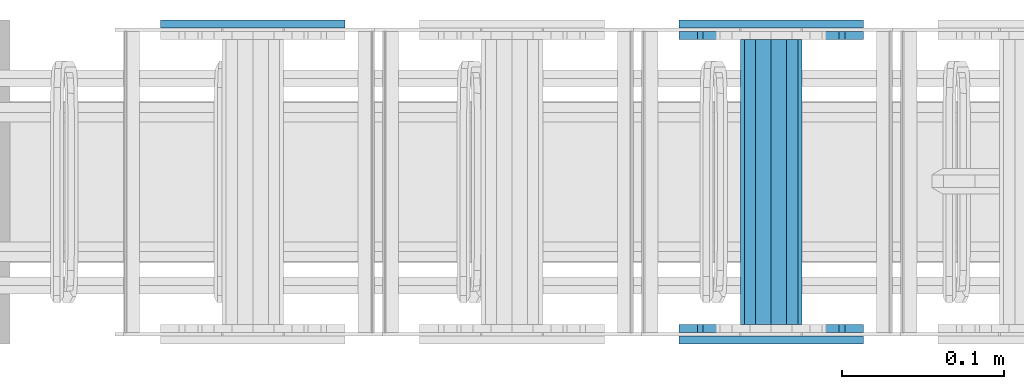
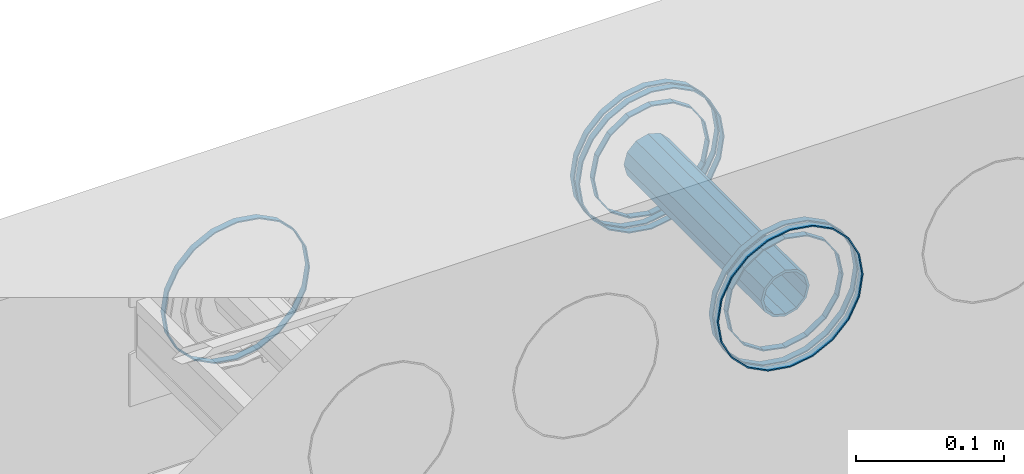
# One storey, part 3 of 11: 8 beams.
"""IFC2X3 building model written with IfcOpenShell, lengths in millimetres."""

import ifcopenshell
import ifcopenshell.guid

model = None  # the IFC model being written
_history = None  # IfcOwnerHistory: only IFC2X3 demands one
_inside = {}  # id of a spatial element -> (the spatial element, [elements in it])
_under = {}  # id of a project, library or spatial element -> (it, [spatial elements below it])
_declared = {}  # id of a project -> (the project, [libraries it declares])
_typed = {}  # id of a type object -> (the type object, [elements of that type])
_made_of = {}  # id of a material, layer set ... -> (it, [elements and type objects made of it])


def new_model(schema):
    """Start an empty IFC model of exactly this schema.

    Asked for "IFC4X3", IfcOpenShell would pick the latest addendum, in which some entities
    have other attributes; the version numbers below select the first issue.
    IFC2X3 requires an IfcOwnerHistory on every rooted entity: one is made here for all.
    """
    global model, _history
    if schema == "IFC4X3":
        model = ifcopenshell.file(schema_version=(4, 3, 0, 0))
    else:
        model = ifcopenshell.file(schema=schema)
    _inside.clear()
    _under.clear()
    _declared.clear()
    _typed.clear()
    _made_of.clear()
    _history = None
    if model.schema == "IFC2X3":
        org = make("IfcOrganization", Name="unknown")
        user = make(
            "IfcPersonAndOrganization",
            ThePerson=make("IfcPerson", FamilyName="unknown"),
            TheOrganization=org,
        )
        app = make(
            "IfcApplication",
            ApplicationDeveloper=org,
            Version="unknown",
            ApplicationFullName="unknown",
            ApplicationIdentifier="unknown",
        )
        _history = make(
            "IfcOwnerHistory",
            OwningUser=user,
            OwningApplication=app,
            ChangeAction="ADDED",
            CreationDate=0,
        )
    return model


def make(cls, **values):
    """One entity of the class cls with the attributes given. An attribute that is None is left unset."""
    return model.create_entity(
        cls, **{name: value for name, value in values.items() if value is not None}
    )


def rooted(cls, **values):
    """An entity with a GlobalId (a new one), such as an element, a storey or a relation."""
    return make(cls, GlobalId=ifcopenshell.guid.new(), OwnerHistory=_history, **values)


def si_unit(unit_type, name, prefix=None):
    """IfcSIUnit, for example si_unit("LENGTHUNIT", "METRE", prefix="MILLI")."""
    return make("IfcSIUnit", UnitType=unit_type, Prefix=prefix, Name=name)


def assignment(units):
    """IfcUnitAssignment: the units of a project."""
    return None if units is None else make("IfcUnitAssignment", Units=units)


def point(xyz):
    """IfcCartesianPoint."""
    return None if xyz is None else make("IfcCartesianPoint", Coordinates=xyz)


def direction(xyz):
    """IfcDirection."""
    return None if xyz is None else make("IfcDirection", DirectionRatios=xyz)


def frame(location, z_axis=None, x_axis=None):
    """IfcAxis2Placement3D, a coordinate frame: its origin and axes. An axis left out is left unset."""
    return make(
        "IfcAxis2Placement3D",
        Location=point(location),
        Axis=direction(z_axis),
        RefDirection=direction(x_axis),
    )


def origin_with_axes():
    """The frame at (0, 0, 0) with the z axis (0, 0, 1) and the x axis (1, 0, 0) written out."""
    return frame((0.0, 0.0, 0.0), z_axis=(0.0, 0.0, 1.0), x_axis=(1.0, 0.0, 0.0))


def place(relative_to, where):
    """IfcLocalPlacement: puts the frame where relative to a parent placement (None: the world)."""
    return make(
        "IfcLocalPlacement", PlacementRelTo=relative_to, RelativePlacement=where
    )


def context(
    kind, dimensions, precision=None, world=None, true_north=None, identifier=None
):
    """IfcGeometricRepresentationContext, for example the 3D "Model" context."""
    return make(
        "IfcGeometricRepresentationContext",
        ContextIdentifier=identifier,
        ContextType=kind,
        CoordinateSpaceDimension=dimensions,
        Precision=precision,
        WorldCoordinateSystem=world,
        TrueNorth=true_north,
    )


def subcontext(parent, identifier, kind, view, scale=None):
    """IfcGeometricRepresentationSubContext, for example "Body" below "Model"."""
    return make(
        "IfcGeometricRepresentationSubContext",
        ContextIdentifier=identifier,
        ContextType=kind,
        ParentContext=parent,
        TargetScale=scale,
        TargetView=view,
    )


def project(units=None, contexts=None):
    """IfcProject with its units and contexts."""
    return rooted(
        "IfcProject",
        Name="project",
        RepresentationContexts=contexts,
        UnitsInContext=assignment(units),
    )


def spatial(cls, under=None, at=None, **own):
    """A site, building, storey or space (cls), placed at a placement, below another one or the project."""
    s = rooted(cls, ObjectPlacement=at, **own)
    if under is not None:
        _under.setdefault(under.id(), (under, []))[1].append(s)
    return s


def faces_of(points, faces, orient=None, outer=None):
    """IfcFace entities. A face is a list of loops; a loop is a list of indices into points, from 0.

    orient and outer hold one flag for each loop. By default every Orientation is true, the
    first loop of a face is its IfcFaceOuterBound and the others are IfcFaceBound.
    """
    made = []
    for i, loops in enumerate(faces):
        bounds = []
        for j, loop in enumerate(loops):
            is_outer = j == 0 if outer is None else outer[i][j]
            bounds.append(
                make(
                    "IfcFaceOuterBound" if is_outer else "IfcFaceBound",
                    Bound=make("IfcPolyLoop", Polygon=[points[k] for k in loop]),
                    Orientation=True if orient is None else orient[i][j],
                )
            )
        made.append(make("IfcFace", Bounds=bounds))
    return made


def faceted_brep(points, faces, orient=None, outer=None, voids=None):
    """IfcFacetedBrep: a solid bounded by flat faces; with voids (closed shells), ...WithVoids."""
    shared = [point(p) for p in points]
    hull = make("IfcClosedShell", CfsFaces=faces_of(shared, faces, orient, outer))
    if voids is None:
        return make("IfcFacetedBrep", Outer=hull)
    return make(
        "IfcFacetedBrepWithVoids",
        Outer=hull,
        Voids=[
            make(cls, CfsFaces=faces_of(shared, fs, o, b)) for cls, fs, o, b in voids
        ],
    )


def shape(context_of_items, identifier, shape_type, items):
    """IfcShapeRepresentation: the items that make up one representation, for example the "Body"."""
    return make(
        "IfcShapeRepresentation",
        ContextOfItems=context_of_items,
        RepresentationIdentifier=identifier,
        RepresentationType=shape_type,
        Items=items,
    )


def material(Name=None, Category=None):
    """IfcMaterial."""
    return make("IfcMaterial", Name=Name, Category=Category)


def made_of(thing, what):
    """Note that an element or type object is made of a material, layer set ...; save() writes the relation."""
    if what is not None:
        _made_of.setdefault(what.id(), (what, []))[1].append(thing)
    return thing


def type_object(cls, material=None, **own):
    """A type object (cls), such as IfcWallType, which elements share."""
    return made_of(rooted(cls, **own), material)


def element(
    cls,
    number,
    at=None,
    inside=None,
    cuts=None,
    type_object=None,
    material=None,
    context=None,
    identifier="Body",
    shape_type=None,
    held_by="IfcProductDefinitionShape",
    body=None,
    shapes=None,
    **own,
):
    """One element of the class cls, such as IfcWall. Its Tag is "e" and its number.

    at: its placement. inside: the storey or other place that contains it. cuts: it is an
    opening in that element (IfcRelVoidsElement). A single representation is given by context,
    identifier, shape_type and body (its items); several are given by shapes. held_by: the class
    of the entity that holds the representations. save() writes the other relations.
    """
    e = rooted(cls, Tag="e%d" % number, ObjectPlacement=at, **own)
    if body is not None:
        shapes = [shape(context, identifier, shape_type, body)]
    if shapes is not None:
        e.Representation = make(held_by, Representations=shapes)
    if inside is not None:
        _inside.setdefault(inside.id(), (inside, []))[1].append(e)
    if cuts is not None:
        rooted(
            "IfcRelVoidsElement", RelatingBuildingElement=cuts, RelatedOpeningElement=e
        )
    if type_object is not None:
        _typed.setdefault(type_object.id(), (type_object, []))[1].append(e)
    return made_of(e, material)


def aggregate(whole, parts):
    """IfcRelAggregates: a whole, such as a stair, and the parts it consists of."""
    return rooted("IfcRelAggregates", RelatingObject=whole, RelatedObjects=parts)


def save(model, path):
    """Write the relations noted so far, then the file.

    IfcRelAggregates (storeys below a building ...), IfcRelContainedInSpatialStructure (elements
    in a storey), IfcRelDefinesByType, IfcRelAssociatesMaterial and IfcRelDeclares: one each for
    every whole, place, type object, material and project.
    """
    for whole, parts in _under.values():
        aggregate(whole, parts)
    for where, things in _inside.values():
        rooted(
            "IfcRelContainedInSpatialStructure",
            RelatedElements=things,
            RelatingStructure=where,
        )
    for kind, things in _typed.values():
        rooted("IfcRelDefinesByType", RelatedObjects=things, RelatingType=kind)
    for what, things in _made_of.values():
        rooted("IfcRelAssociatesMaterial", RelatedObjects=things, RelatingMaterial=what)
    for by, libraries in _declared.values():
        rooted("IfcRelDeclares", RelatingContext=by, RelatedDefinitions=libraries)
    model.write(path)


model = new_model("IFC2X3")

# Units and contexts
model_context = context("Model", 3, precision=1e-05, world=origin_with_axes())
body_context = subcontext(model_context, "Body", "Model", "MODEL_VIEW")
ifc_project = project(units=[si_unit("LENGTHUNIT", "METRE", prefix="MILLI"), si_unit("AREAUNIT", "SQUARE_METRE"), si_unit("VOLUMEUNIT", "CUBIC_METRE"), si_unit("MASSUNIT", "GRAM", prefix="KILO"), si_unit("TIMEUNIT", "SECOND"), si_unit("PLANEANGLEUNIT", "RADIAN"), si_unit("SOLIDANGLEUNIT", "STERADIAN"), si_unit("THERMODYNAMICTEMPERATUREUNIT", "DEGREE_CELSIUS"), si_unit("LUMINOUSINTENSITYUNIT", "LUMEN")], contexts=[model_context])

# Site, building, storey
site_placement = place(None, origin_with_axes())
site = spatial("IfcSite", under=ifc_project, at=site_placement, CompositionType="ELEMENT")
building_placement = place(site_placement, origin_with_axes())
building = spatial("IfcBuilding", under=site, at=building_placement, Name="Undefined", CompositionType="ELEMENT")
storey_placement = place(building_placement, origin_with_axes())
storey = spatial("IfcBuildingStorey", under=building, at=storey_placement, Name="Undefined", CompositionType="ELEMENT", Elevation=0.0)

# Beams
ifc_material = material(Name="STEEL/Steel_Undefined")
beam_type_1 = type_object("IfcBeamType", PredefinedType="NOTDEFINED")
beam_1_placement = place(storey_placement, frame((1819.98457749309, -5.08317012009296, 2335.01381840039), z_axis=(-1.0, 0.0, 0.0), x_axis=(0.0, 1.0, 0.0)))
element("IfcBeam", 1, at=beam_1_placement, inside=storey, type_object=beam_type_1, material=ifc_material, Name="K160", context=body_context, shape_type="Brep", body=[
    faceted_brep([(0.0, -56.0, 0.0), (0.0, -53.2591649125284, 17.3049516849972), (5.0, -53.2591649125284, 17.3049516849972), (5.0, -56.0, 0.0), (0.0, -45.3049516849969, 32.9159741283786), (5.0, -45.3049516849969, 32.9159741283786), (0.0, -32.9159741283784, 45.3049516849972), (5.0, -32.9159741283784, 45.3049516849972), (0.0, -17.3049516849969, 53.2591649125286), (5.0, -17.3049516849969, 53.2591649125286), (0.0, 0.0, 56.0), (5.0, 0.0, 56.0), (0.0, 17.3049516849969, 53.2591649125286), (5.0, 17.3049516849969, 53.2591649125286), (0.0, 32.9159741283784, 45.3049516849972), (5.0, 32.9159741283784, 45.3049516849972), (0.0, 45.3049516849969, 32.9159741283786), (5.0, 45.3049516849969, 32.9159741283786), (0.0, 53.2591649125284, 17.3049516849972), (5.0, 53.2591649125284, 17.3049516849972), (0.0, 56.0, 0.0), (5.0, 56.0, 0.0), (0.0, 53.2591649125284, -17.3049516849972), (5.0, 53.2591649125284, -17.3049516849972), (0.0, 45.3049516849969, -32.9159741283786), (5.0, 45.3049516849969, -32.9159741283786), (0.0, 32.9159741283784, -45.3049516849972), (5.0, 32.9159741283784, -45.3049516849972), (0.0, 17.3049516849969, -53.2591649125286), (5.0, 17.3049516849969, -53.2591649125286), (0.0, 0.0, -56.0), (5.0, 0.0, -56.0), (0.0, -17.3049516849969, -53.2591649125286), (5.0, -17.3049516849969, -53.2591649125286), (0.0, -32.9159741283784, -45.3049516849972), (5.0, -32.9159741283784, -45.3049516849972), (0.0, -45.3049516849969, -32.9159741283786), (5.0, -45.3049516849969, -32.9159741283786), (0.0, -53.2591649125284, -17.3049516849972), (5.0, -53.2591649125284, -17.3049516849972), (0.0, -57.0, 0.0), (0.0, -54.2102214288238, -17.613968679372), (5.0, -54.2102214288238, -17.613968679372), (5.0, -57.0, 0.0), (0.0, -46.1139686793722, -33.503759380671), (5.0, -46.1139686793722, -33.503759380671), (0.0, -33.503759380671, -46.113968679372), (5.0, -33.503759380671, -46.113968679372), (0.0, -17.6139686793722, -54.2102214288238), (5.0, -17.6139686793722, -54.2102214288238), (0.0, 0.0, -57.0), (5.0, 0.0, -57.0), (0.0, 17.6139686793722, -54.2102214288238), (5.0, 17.6139686793722, -54.2102214288238), (0.0, 33.503759380671, -46.113968679372), (5.0, 33.503759380671, -46.113968679372), (0.0, 46.1139686793722, -33.503759380671), (5.0, 46.1139686793722, -33.503759380671), (0.0, 54.2102214288238, -17.613968679372), (5.0, 54.2102214288238, -17.613968679372), (0.0, 57.0, 0.0), (5.0, 57.0, 0.0), (0.0, 54.2102214288238, 17.613968679372), (5.0, 54.2102214288238, 17.613968679372), (0.0, 46.1139686793722, 33.503759380671), (5.0, 46.1139686793722, 33.503759380671), (0.0, 33.503759380671, 46.113968679372), (5.0, 33.503759380671, 46.113968679372), (0.0, 17.6139686793722, 54.2102214288238), (5.0, 17.6139686793722, 54.2102214288238), (0.0, 0.0, 57.0), (5.0, 0.0, 57.0), (0.0, -17.6139686793722, 54.2102214288238), (5.0, -17.6139686793722, 54.2102214288238), (0.0, -33.503759380671, 46.113968679372), (5.0, -33.503759380671, 46.113968679372), (0.0, -46.1139686793722, 33.503759380671), (5.0, -46.1139686793722, 33.503759380671), (0.0, -54.2102214288238, 17.613968679372), (5.0, -54.2102214288238, 17.613968679372)], [[[0, 1, 2, 3]], [[1, 4, 5, 2]], [[4, 6, 7, 5]], [[6, 8, 9, 7]], [[8, 10, 11, 9]], [[10, 12, 13, 11]], [[12, 14, 15, 13]], [[14, 16, 17, 15]], [[16, 18, 19, 17]], [[18, 20, 21, 19]], [[20, 22, 23, 21]], [[22, 24, 25, 23]], [[24, 26, 27, 25]], [[26, 28, 29, 27]], [[28, 30, 31, 29]], [[30, 32, 33, 31]], [[32, 34, 35, 33]], [[34, 36, 37, 35]], [[36, 38, 39, 37]], [[38, 0, 3, 39]], [[40, 41, 42, 43]], [[41, 44, 45, 42]], [[44, 46, 47, 45]], [[46, 48, 49, 47]], [[48, 50, 51, 49]], [[50, 52, 53, 51]], [[52, 54, 55, 53]], [[54, 56, 57, 55]], [[56, 58, 59, 57]], [[58, 60, 61, 59]], [[60, 62, 63, 61]], [[62, 64, 65, 63]], [[64, 66, 67, 65]], [[66, 68, 69, 67]], [[68, 70, 71, 69]], [[70, 72, 73, 71]], [[72, 74, 75, 73]], [[74, 76, 77, 75]], [[76, 78, 79, 77]], [[78, 40, 43, 79]], [[45, 47, 49, 51, 53, 55, 57, 59, 61, 63, 65, 67, 69, 71, 73, 75, 77, 79, 43, 42], [5, 7, 9, 11, 13, 15, 17, 19, 21, 23, 25, 27, 29, 31, 33, 35, 37, 39, 3, 2]], [[78, 76, 74, 72, 70, 68, 66, 64, 62, 60, 58, 56, 54, 52, 50, 48, 46, 44, 41, 40], [38, 36, 34, 32, 30, 28, 26, 24, 22, 20, 18, 16, 14, 12, 10, 8, 6, 4, 1, 0]]]),
])
beam_2_placement = place(storey_placement, frame((1499.98457749309, -5.08317012009302, 2335.01381840039), z_axis=(-1.0, 0.0, 0.0), x_axis=(0.0, 1.0, 0.0)))
element("IfcBeam", 2, at=beam_2_placement, inside=storey, type_object=beam_type_1, material=ifc_material, Name="K160", context=body_context, shape_type="Brep", body=[
    faceted_brep([(0.0, -56.0, 0.0), (0.0, -53.2591649125284, 17.3049516849972), (5.0, -53.2591649125284, 17.3049516849972), (5.0, -56.0, 0.0), (0.0, -45.3049516849969, 32.9159741283786), (5.0, -45.3049516849969, 32.9159741283786), (0.0, -32.9159741283784, 45.3049516849972), (5.0, -32.9159741283784, 45.3049516849972), (0.0, -17.3049516849969, 53.2591649125286), (5.0, -17.3049516849969, 53.2591649125286), (0.0, 0.0, 56.0), (5.0, 0.0, 56.0), (0.0, 17.3049516849969, 53.2591649125286), (5.0, 17.3049516849969, 53.2591649125286), (0.0, 32.9159741283784, 45.3049516849972), (5.0, 32.9159741283784, 45.3049516849972), (0.0, 45.3049516849969, 32.9159741283786), (5.0, 45.3049516849969, 32.9159741283786), (0.0, 53.2591649125284, 17.3049516849972), (5.0, 53.2591649125284, 17.3049516849972), (0.0, 56.0, 0.0), (5.0, 56.0, 0.0), (0.0, 53.2591649125284, -17.3049516849972), (5.0, 53.2591649125284, -17.3049516849972), (0.0, 45.3049516849969, -32.9159741283786), (5.0, 45.3049516849969, -32.9159741283786), (0.0, 32.9159741283784, -45.3049516849972), (5.0, 32.9159741283784, -45.3049516849972), (0.0, 17.3049516849969, -53.2591649125286), (5.0, 17.3049516849969, -53.2591649125286), (0.0, 0.0, -56.0), (5.0, 0.0, -56.0), (0.0, -17.3049516849969, -53.2591649125286), (5.0, -17.3049516849969, -53.2591649125286), (0.0, -32.9159741283784, -45.3049516849972), (5.0, -32.9159741283784, -45.3049516849972), (0.0, -45.3049516849969, -32.9159741283786), (5.0, -45.3049516849969, -32.9159741283786), (0.0, -53.2591649125284, -17.3049516849972), (5.0, -53.2591649125284, -17.3049516849972), (0.0, -57.0, 0.0), (0.0, -54.2102214288238, -17.613968679372), (5.0, -54.2102214288238, -17.613968679372), (5.0, -57.0, 0.0), (0.0, -46.1139686793722, -33.503759380671), (5.0, -46.1139686793722, -33.503759380671), (0.0, -33.503759380671, -46.113968679372), (5.0, -33.503759380671, -46.113968679372), (0.0, -17.6139686793722, -54.2102214288238), (5.0, -17.6139686793722, -54.2102214288238), (0.0, 0.0, -57.0), (5.0, 0.0, -57.0), (0.0, 17.6139686793722, -54.2102214288238), (5.0, 17.6139686793722, -54.2102214288238), (0.0, 33.503759380671, -46.113968679372), (5.0, 33.503759380671, -46.113968679372), (0.0, 46.1139686793722, -33.503759380671), (5.0, 46.1139686793722, -33.503759380671), (0.0, 54.2102214288238, -17.613968679372), (5.0, 54.2102214288238, -17.613968679372), (0.0, 57.0, 0.0), (5.0, 57.0, 0.0), (0.0, 54.2102214288238, 17.613968679372), (5.0, 54.2102214288238, 17.613968679372), (0.0, 46.1139686793722, 33.503759380671), (5.0, 46.1139686793722, 33.503759380671), (0.0, 33.503759380671, 46.113968679372), (5.0, 33.503759380671, 46.113968679372), (0.0, 17.6139686793722, 54.2102214288238), (5.0, 17.6139686793722, 54.2102214288238), (0.0, 0.0, 57.0), (5.0, 0.0, 57.0), (0.0, -17.6139686793722, 54.2102214288238), (5.0, -17.6139686793722, 54.2102214288238), (0.0, -33.503759380671, 46.113968679372), (5.0, -33.503759380671, 46.113968679372), (0.0, -46.1139686793722, 33.503759380671), (5.0, -46.1139686793722, 33.503759380671), (0.0, -54.2102214288238, 17.613968679372), (5.0, -54.2102214288238, 17.613968679372)], [[[0, 1, 2, 3]], [[1, 4, 5, 2]], [[4, 6, 7, 5]], [[6, 8, 9, 7]], [[8, 10, 11, 9]], [[10, 12, 13, 11]], [[12, 14, 15, 13]], [[14, 16, 17, 15]], [[16, 18, 19, 17]], [[18, 20, 21, 19]], [[20, 22, 23, 21]], [[22, 24, 25, 23]], [[24, 26, 27, 25]], [[26, 28, 29, 27]], [[28, 30, 31, 29]], [[30, 32, 33, 31]], [[32, 34, 35, 33]], [[34, 36, 37, 35]], [[36, 38, 39, 37]], [[38, 0, 3, 39]], [[40, 41, 42, 43]], [[41, 44, 45, 42]], [[44, 46, 47, 45]], [[46, 48, 49, 47]], [[48, 50, 51, 49]], [[50, 52, 53, 51]], [[52, 54, 55, 53]], [[54, 56, 57, 55]], [[56, 58, 59, 57]], [[58, 60, 61, 59]], [[60, 62, 63, 61]], [[62, 64, 65, 63]], [[64, 66, 67, 65]], [[66, 68, 69, 67]], [[68, 70, 71, 69]], [[70, 72, 73, 71]], [[72, 74, 75, 73]], [[74, 76, 77, 75]], [[76, 78, 79, 77]], [[78, 40, 43, 79]], [[45, 47, 49, 51, 53, 55, 57, 59, 61, 63, 65, 67, 69, 71, 73, 75, 77, 79, 43, 42], [5, 7, 9, 11, 13, 15, 17, 19, 21, 23, 25, 27, 29, 31, 33, 35, 37, 39, 3, 2]], [[78, 76, 74, 72, 70, 68, 66, 64, 62, 60, 58, 56, 54, 52, 50, 48, 46, 44, 41, 40], [38, 36, 34, 32, 30, 28, 26, 24, 22, 20, 18, 16, 14, 12, 10, 8, 6, 4, 1, 0]]]),
])
beam_3_placement = place(storey_placement, frame((1819.98457749309, -200.083170120093, 2335.01381840039), z_axis=(-1.0, 0.0, 0.0), x_axis=(0.0, 1.0, 0.0)))
element("IfcBeam", 3, at=beam_3_placement, inside=storey, type_object=beam_type_1, material=ifc_material, context=body_context, shape_type="Brep", body=[
    faceted_brep([(0.0, -56.0, 0.0), (0.0, -53.2591649125284, 17.3049516849972), (5.0, -53.2591649125284, 17.3049516849972), (5.0, -56.0, 0.0), (0.0, -45.3049516849969, 32.9159741283786), (5.0, -45.3049516849969, 32.9159741283786), (0.0, -32.9159741283784, 45.3049516849972), (5.0, -32.9159741283784, 45.3049516849972), (0.0, -17.3049516849969, 53.2591649125286), (5.0, -17.3049516849969, 53.2591649125286), (0.0, 0.0, 56.0), (5.0, 0.0, 56.0), (0.0, 17.3049516849969, 53.2591649125286), (5.0, 17.3049516849969, 53.2591649125286), (0.0, 32.9159741283784, 45.3049516849972), (5.0, 32.9159741283784, 45.3049516849972), (0.0, 45.3049516849969, 32.9159741283786), (5.0, 45.3049516849969, 32.9159741283786), (0.0, 53.2591649125284, 17.3049516849972), (5.0, 53.2591649125284, 17.3049516849972), (0.0, 56.0, 0.0), (5.0, 56.0, 0.0), (0.0, 53.2591649125284, -17.3049516849972), (5.0, 53.2591649125284, -17.3049516849972), (0.0, 45.3049516849969, -32.9159741283786), (5.0, 45.3049516849969, -32.9159741283786), (0.0, 32.9159741283784, -45.3049516849972), (5.0, 32.9159741283784, -45.3049516849972), (0.0, 17.3049516849969, -53.2591649125286), (5.0, 17.3049516849969, -53.2591649125286), (0.0, 0.0, -56.0), (5.0, 0.0, -56.0), (0.0, -17.3049516849969, -53.2591649125286), (5.0, -17.3049516849969, -53.2591649125286), (0.0, -32.9159741283784, -45.3049516849972), (5.0, -32.9159741283784, -45.3049516849972), (0.0, -45.3049516849969, -32.9159741283786), (5.0, -45.3049516849969, -32.9159741283786), (0.0, -53.2591649125284, -17.3049516849972), (5.0, -53.2591649125284, -17.3049516849972), (0.0, -57.0, 0.0), (0.0, -54.2102214288238, -17.613968679372), (5.0, -54.2102214288238, -17.613968679372), (5.0, -57.0, 0.0), (0.0, -46.1139686793722, -33.503759380671), (5.0, -46.1139686793722, -33.503759380671), (0.0, -33.503759380671, -46.113968679372), (5.0, -33.503759380671, -46.113968679372), (0.0, -17.6139686793722, -54.2102214288238), (5.0, -17.6139686793722, -54.2102214288238), (0.0, 0.0, -57.0), (5.0, 0.0, -57.0), (0.0, 17.6139686793722, -54.2102214288238), (5.0, 17.6139686793722, -54.2102214288238), (0.0, 33.503759380671, -46.113968679372), (5.0, 33.503759380671, -46.113968679372), (0.0, 46.1139686793722, -33.503759380671), (5.0, 46.1139686793722, -33.503759380671), (0.0, 54.2102214288238, -17.613968679372), (5.0, 54.2102214288238, -17.613968679372), (0.0, 57.0, 0.0), (5.0, 57.0, 0.0), (0.0, 54.2102214288238, 17.613968679372), (5.0, 54.2102214288238, 17.613968679372), (0.0, 46.1139686793722, 33.503759380671), (5.0, 46.1139686793722, 33.503759380671), (0.0, 33.503759380671, 46.113968679372), (5.0, 33.503759380671, 46.113968679372), (0.0, 17.6139686793722, 54.2102214288238), (5.0, 17.6139686793722, 54.2102214288238), (0.0, 0.0, 57.0), (5.0, 0.0, 57.0), (0.0, -17.6139686793722, 54.2102214288238), (5.0, -17.6139686793722, 54.2102214288238), (0.0, -33.503759380671, 46.113968679372), (5.0, -33.503759380671, 46.113968679372), (0.0, -46.1139686793722, 33.503759380671), (5.0, -46.1139686793722, 33.503759380671), (0.0, -54.2102214288238, 17.613968679372), (5.0, -54.2102214288238, 17.613968679372)], [[[0, 1, 2, 3]], [[1, 4, 5, 2]], [[4, 6, 7, 5]], [[6, 8, 9, 7]], [[8, 10, 11, 9]], [[10, 12, 13, 11]], [[12, 14, 15, 13]], [[14, 16, 17, 15]], [[16, 18, 19, 17]], [[18, 20, 21, 19]], [[20, 22, 23, 21]], [[22, 24, 25, 23]], [[24, 26, 27, 25]], [[26, 28, 29, 27]], [[28, 30, 31, 29]], [[30, 32, 33, 31]], [[32, 34, 35, 33]], [[34, 36, 37, 35]], [[36, 38, 39, 37]], [[38, 0, 3, 39]], [[40, 41, 42, 43]], [[41, 44, 45, 42]], [[44, 46, 47, 45]], [[46, 48, 49, 47]], [[48, 50, 51, 49]], [[50, 52, 53, 51]], [[52, 54, 55, 53]], [[54, 56, 57, 55]], [[56, 58, 59, 57]], [[58, 60, 61, 59]], [[60, 62, 63, 61]], [[62, 64, 65, 63]], [[64, 66, 67, 65]], [[66, 68, 69, 67]], [[68, 70, 71, 69]], [[70, 72, 73, 71]], [[72, 74, 75, 73]], [[74, 76, 77, 75]], [[76, 78, 79, 77]], [[78, 40, 43, 79]], [[45, 47, 49, 51, 53, 55, 57, 59, 61, 63, 65, 67, 69, 71, 73, 75, 77, 79, 43, 42], [5, 7, 9, 11, 13, 15, 17, 19, 21, 23, 25, 27, 29, 31, 33, 35, 37, 39, 3, 2]], [[78, 76, 74, 72, 70, 68, 66, 64, 62, 60, 58, 56, 54, 52, 50, 48, 46, 44, 41, 40], [38, 36, 34, 32, 30, 28, 26, 24, 22, 20, 18, 16, 14, 12, 10, 8, 6, 4, 1, 0]]]),
])
beam_4_placement = place(storey_placement, frame((1819.98457749309, -12.083170120093, 2335.01381840039), z_axis=(-1.0, 0.0, 0.0), x_axis=(0.0, 1.0, 0.0)))
element("IfcBeam", 4, at=beam_4_placement, inside=storey, type_object=beam_type_1, material=ifc_material, context=body_context, shape_type="Brep", body=[
    faceted_brep([(0.0, -56.0, 0.0), (0.0, -53.2591649125284, 17.3049516849972), (5.0, -53.2591649125284, 17.3049516849972), (5.0, -56.0, 0.0), (0.0, -45.3049516849969, 32.9159741283786), (5.0, -45.3049516849969, 32.9159741283786), (0.0, -32.9159741283784, 45.3049516849972), (5.0, -32.9159741283784, 45.3049516849972), (0.0, -17.3049516849969, 53.2591649125286), (5.0, -17.3049516849969, 53.2591649125286), (0.0, 0.0, 56.0), (5.0, 0.0, 56.0), (0.0, 17.3049516849969, 53.2591649125286), (5.0, 17.3049516849969, 53.2591649125286), (0.0, 32.9159741283784, 45.3049516849972), (5.0, 32.9159741283784, 45.3049516849972), (0.0, 45.3049516849969, 32.9159741283786), (5.0, 45.3049516849969, 32.9159741283786), (0.0, 53.2591649125284, 17.3049516849972), (5.0, 53.2591649125284, 17.3049516849972), (0.0, 56.0, 0.0), (5.0, 56.0, 0.0), (0.0, 53.2591649125284, -17.3049516849972), (5.0, 53.2591649125284, -17.3049516849972), (0.0, 45.3049516849969, -32.9159741283786), (5.0, 45.3049516849969, -32.9159741283786), (0.0, 32.9159741283784, -45.3049516849972), (5.0, 32.9159741283784, -45.3049516849972), (0.0, 17.3049516849969, -53.2591649125286), (5.0, 17.3049516849969, -53.2591649125286), (0.0, 0.0, -56.0), (5.0, 0.0, -56.0), (0.0, -17.3049516849969, -53.2591649125286), (5.0, -17.3049516849969, -53.2591649125286), (0.0, -32.9159741283784, -45.3049516849972), (5.0, -32.9159741283784, -45.3049516849972), (0.0, -45.3049516849969, -32.9159741283786), (5.0, -45.3049516849969, -32.9159741283786), (0.0, -53.2591649125284, -17.3049516849972), (5.0, -53.2591649125284, -17.3049516849972), (0.0, -57.0, 0.0), (0.0, -54.2102214288238, -17.613968679372), (5.0, -54.2102214288238, -17.613968679372), (5.0, -57.0, 0.0), (0.0, -46.1139686793722, -33.503759380671), (5.0, -46.1139686793722, -33.503759380671), (0.0, -33.503759380671, -46.113968679372), (5.0, -33.503759380671, -46.113968679372), (0.0, -17.6139686793722, -54.2102214288238), (5.0, -17.6139686793722, -54.2102214288238), (0.0, 0.0, -57.0), (5.0, 0.0, -57.0), (0.0, 17.6139686793722, -54.2102214288238), (5.0, 17.6139686793722, -54.2102214288238), (0.0, 33.503759380671, -46.113968679372), (5.0, 33.503759380671, -46.113968679372), (0.0, 46.1139686793722, -33.503759380671), (5.0, 46.1139686793722, -33.503759380671), (0.0, 54.2102214288238, -17.613968679372), (5.0, 54.2102214288238, -17.613968679372), (0.0, 57.0, 0.0), (5.0, 57.0, 0.0), (0.0, 54.2102214288238, 17.613968679372), (5.0, 54.2102214288238, 17.613968679372), (0.0, 46.1139686793722, 33.503759380671), (5.0, 46.1139686793722, 33.503759380671), (0.0, 33.503759380671, 46.113968679372), (5.0, 33.503759380671, 46.113968679372), (0.0, 17.6139686793722, 54.2102214288238), (5.0, 17.6139686793722, 54.2102214288238), (0.0, 0.0, 57.0), (5.0, 0.0, 57.0), (0.0, -17.6139686793722, 54.2102214288238), (5.0, -17.6139686793722, 54.2102214288238), (0.0, -33.503759380671, 46.113968679372), (5.0, -33.503759380671, 46.113968679372), (0.0, -46.1139686793722, 33.503759380671), (5.0, -46.1139686793722, 33.503759380671), (0.0, -54.2102214288238, 17.613968679372), (5.0, -54.2102214288238, 17.613968679372)], [[[0, 1, 2, 3]], [[1, 4, 5, 2]], [[4, 6, 7, 5]], [[6, 8, 9, 7]], [[8, 10, 11, 9]], [[10, 12, 13, 11]], [[12, 14, 15, 13]], [[14, 16, 17, 15]], [[16, 18, 19, 17]], [[18, 20, 21, 19]], [[20, 22, 23, 21]], [[22, 24, 25, 23]], [[24, 26, 27, 25]], [[26, 28, 29, 27]], [[28, 30, 31, 29]], [[30, 32, 33, 31]], [[32, 34, 35, 33]], [[34, 36, 37, 35]], [[36, 38, 39, 37]], [[38, 0, 3, 39]], [[40, 41, 42, 43]], [[41, 44, 45, 42]], [[44, 46, 47, 45]], [[46, 48, 49, 47]], [[48, 50, 51, 49]], [[50, 52, 53, 51]], [[52, 54, 55, 53]], [[54, 56, 57, 55]], [[56, 58, 59, 57]], [[58, 60, 61, 59]], [[60, 62, 63, 61]], [[62, 64, 65, 63]], [[64, 66, 67, 65]], [[66, 68, 69, 67]], [[68, 70, 71, 69]], [[70, 72, 73, 71]], [[72, 74, 75, 73]], [[74, 76, 77, 75]], [[76, 78, 79, 77]], [[78, 40, 43, 79]], [[45, 47, 49, 51, 53, 55, 57, 59, 61, 63, 65, 67, 69, 71, 73, 75, 77, 79, 43, 42], [5, 7, 9, 11, 13, 15, 17, 19, 21, 23, 25, 27, 29, 31, 33, 35, 37, 39, 3, 2]], [[78, 76, 74, 72, 70, 68, 66, 64, 62, 60, 58, 56, 54, 52, 50, 48, 46, 44, 41, 40], [38, 36, 34, 32, 30, 28, 26, 24, 22, 20, 18, 16, 14, 12, 10, 8, 6, 4, 1, 0]]]),
])
beam_5_placement = place(storey_placement, frame((1819.98457749309, -188.083170120093, 2335.01381840039), z_axis=(-1.0, 0.0, 0.0), x_axis=(0.0, -1.0, 0.0)))
element("IfcBeam", 5, at=beam_5_placement, inside=storey, type_object=beam_type_1, material=ifc_material, context=body_context, shape_type="Brep", body=[
    faceted_brep([(0.0, -56.0, 0.0), (0.0, -53.2591649125284, 17.3049516849972), (5.0, -53.2591649125284, 17.3049516849972), (5.0, -56.0, 0.0), (0.0, -45.3049516849969, 32.9159741283786), (5.0, -45.3049516849969, 32.9159741283786), (0.0, -32.9159741283784, 45.3049516849972), (5.0, -32.9159741283784, 45.3049516849972), (0.0, -17.3049516849969, 53.2591649125286), (5.0, -17.3049516849969, 53.2591649125286), (0.0, 0.0, 56.0), (5.0, 0.0, 56.0), (0.0, 17.3049516849969, 53.2591649125286), (5.0, 17.3049516849969, 53.2591649125286), (0.0, 32.9159741283784, 45.3049516849972), (5.0, 32.9159741283784, 45.3049516849972), (0.0, 45.3049516849969, 32.9159741283786), (5.0, 45.3049516849969, 32.9159741283786), (0.0, 53.2591649125284, 17.3049516849972), (5.0, 53.2591649125284, 17.3049516849972), (0.0, 56.0, 0.0), (5.0, 56.0, 0.0), (0.0, 53.2591649125284, -17.3049516849972), (5.0, 53.2591649125284, -17.3049516849972), (0.0, 45.3049516849969, -32.9159741283786), (5.0, 45.3049516849969, -32.9159741283786), (0.0, 32.9159741283784, -45.3049516849972), (5.0, 32.9159741283784, -45.3049516849972), (0.0, 17.3049516849969, -53.2591649125286), (5.0, 17.3049516849969, -53.2591649125286), (0.0, 0.0, -56.0), (5.0, 0.0, -56.0), (0.0, -17.3049516849969, -53.2591649125286), (5.0, -17.3049516849969, -53.2591649125286), (0.0, -32.9159741283784, -45.3049516849972), (5.0, -32.9159741283784, -45.3049516849972), (0.0, -45.3049516849969, -32.9159741283786), (5.0, -45.3049516849969, -32.9159741283786), (0.0, -53.2591649125284, -17.3049516849972), (5.0, -53.2591649125284, -17.3049516849972), (0.0, -57.0, 0.0), (0.0, -54.2102214288238, -17.613968679372), (5.0, -54.2102214288238, -17.613968679372), (5.0, -57.0, 0.0), (0.0, -46.1139686793722, -33.503759380671), (5.0, -46.1139686793722, -33.503759380671), (0.0, -33.503759380671, -46.113968679372), (5.0, -33.503759380671, -46.113968679372), (0.0, -17.6139686793722, -54.2102214288238), (5.0, -17.6139686793722, -54.2102214288238), (0.0, 0.0, -57.0), (5.0, 0.0, -57.0), (0.0, 17.6139686793722, -54.2102214288238), (5.0, 17.6139686793722, -54.2102214288238), (0.0, 33.503759380671, -46.113968679372), (5.0, 33.503759380671, -46.113968679372), (0.0, 46.1139686793722, -33.503759380671), (5.0, 46.1139686793722, -33.503759380671), (0.0, 54.2102214288238, -17.613968679372), (5.0, 54.2102214288238, -17.613968679372), (0.0, 57.0, 0.0), (5.0, 57.0, 0.0), (0.0, 54.2102214288238, 17.613968679372), (5.0, 54.2102214288238, 17.613968679372), (0.0, 46.1139686793722, 33.503759380671), (5.0, 46.1139686793722, 33.503759380671), (0.0, 33.503759380671, 46.113968679372), (5.0, 33.503759380671, 46.113968679372), (0.0, 17.6139686793722, 54.2102214288238), (5.0, 17.6139686793722, 54.2102214288238), (0.0, 0.0, 57.0), (5.0, 0.0, 57.0), (0.0, -17.6139686793722, 54.2102214288238), (5.0, -17.6139686793722, 54.2102214288238), (0.0, -33.503759380671, 46.113968679372), (5.0, -33.503759380671, 46.113968679372), (0.0, -46.1139686793722, 33.503759380671), (5.0, -46.1139686793722, 33.503759380671), (0.0, -54.2102214288238, 17.613968679372), (5.0, -54.2102214288238, 17.613968679372)], [[[0, 1, 2, 3]], [[1, 4, 5, 2]], [[4, 6, 7, 5]], [[6, 8, 9, 7]], [[8, 10, 11, 9]], [[10, 12, 13, 11]], [[12, 14, 15, 13]], [[14, 16, 17, 15]], [[16, 18, 19, 17]], [[18, 20, 21, 19]], [[20, 22, 23, 21]], [[22, 24, 25, 23]], [[24, 26, 27, 25]], [[26, 28, 29, 27]], [[28, 30, 31, 29]], [[30, 32, 33, 31]], [[32, 34, 35, 33]], [[34, 36, 37, 35]], [[36, 38, 39, 37]], [[38, 0, 3, 39]], [[40, 41, 42, 43]], [[41, 44, 45, 42]], [[44, 46, 47, 45]], [[46, 48, 49, 47]], [[48, 50, 51, 49]], [[50, 52, 53, 51]], [[52, 54, 55, 53]], [[54, 56, 57, 55]], [[56, 58, 59, 57]], [[58, 60, 61, 59]], [[60, 62, 63, 61]], [[62, 64, 65, 63]], [[64, 66, 67, 65]], [[66, 68, 69, 67]], [[68, 70, 71, 69]], [[70, 72, 73, 71]], [[72, 74, 75, 73]], [[74, 76, 77, 75]], [[76, 78, 79, 77]], [[78, 40, 43, 79]], [[45, 47, 49, 51, 53, 55, 57, 59, 61, 63, 65, 67, 69, 71, 73, 75, 77, 79, 43, 42], [5, 7, 9, 11, 13, 15, 17, 19, 21, 23, 25, 27, 29, 31, 33, 35, 37, 39, 3, 2]], [[78, 76, 74, 72, 70, 68, 66, 64, 62, 60, 58, 56, 54, 52, 50, 48, 46, 44, 41, 40], [38, 36, 34, 32, 30, 28, 26, 24, 22, 20, 18, 16, 14, 12, 10, 8, 6, 4, 1, 0]]]),
])
beam_type_2 = type_object("IfcBeamType", PredefinedType="NOTDEFINED")
beam_6_placement = place(storey_placement, frame((1819.98457749309, -12.083170120093, 2335.01381840039), z_axis=(-1.0, 0.0, 0.0), x_axis=(0.0, 1.0, 0.0)))
element("IfcBeam", 6, at=beam_6_placement, inside=storey, type_object=beam_type_2, material=ifc_material, context=body_context, shape_type="Brep", body=[
    faceted_brep([(0.0, -44.5, 0.0), (0.0, -41.1126391967523, 17.0294127402465), (5.0, -41.1126391967523, 17.0294127402465), (5.0, -44.5, 0.0), (0.0, -31.4662517628012, 31.4662517628014), (5.0, -31.4662517628012, 31.4662517628014), (0.0, -17.0294127402467, 41.1126391967523), (5.0, -17.0294127402467, 41.1126391967523), (0.0, 0.0, 44.5), (5.0, 0.0, 44.5), (0.0, 17.0294127402467, 41.1126391967523), (5.0, 17.0294127402467, 41.1126391967523), (0.0, 31.4662517628012, 31.4662517628014), (5.0, 31.4662517628012, 31.4662517628014), (0.0, 41.1126391967523, 17.0294127402465), (5.0, 41.1126391967523, 17.0294127402465), (0.0, 44.5, 0.0), (5.0, 44.5, 0.0), (0.0, 41.1126391967523, -17.0294127402465), (5.0, 41.1126391967523, -17.0294127402465), (0.0, 31.4662517628012, -31.4662517628014), (5.0, 31.4662517628012, -31.4662517628014), (0.0, 17.0294127402467, -41.1126391967523), (5.0, 17.0294127402467, -41.1126391967523), (0.0, 0.0, -44.5), (5.0, 0.0, -44.5), (0.0, -17.0294127402467, -41.1126391967523), (5.0, -17.0294127402467, -41.1126391967523), (0.0, -31.4662517628012, -31.4662517628014), (5.0, -31.4662517628012, -31.4662517628014), (0.0, -41.1126391967523, -17.0294127402465), (5.0, -41.1126391967523, -17.0294127402465), (0.0, -45.5, 0.0), (0.0, -42.0365187292637, -17.4120961726117), (5.0, -42.0365187292637, -17.4120961726117), (5.0, -45.5, 0.0), (0.0, -32.1733585439879, -32.1733585439879), (5.0, -32.1733585439879, -32.1733585439879), (0.0, -17.4120961726117, -42.0365187292634), (5.0, -17.4120961726117, -42.0365187292634), (0.0, 0.0, -45.5), (5.0, 0.0, -45.5), (0.0, 17.4120961726117, -42.0365187292634), (5.0, 17.4120961726117, -42.0365187292634), (0.0, 32.1733585439879, -32.1733585439879), (5.0, 32.1733585439879, -32.1733585439879), (0.0, 42.0365187292637, -17.4120961726117), (5.0, 42.0365187292637, -17.4120961726117), (0.0, 45.5, 0.0), (5.0, 45.5, 0.0), (0.0, 42.0365187292637, 17.4120961726117), (5.0, 42.0365187292637, 17.4120961726117), (0.0, 32.1733585439879, 32.1733585439879), (5.0, 32.1733585439879, 32.1733585439879), (0.0, 17.4120961726117, 42.0365187292634), (5.0, 17.4120961726117, 42.0365187292634), (0.0, 0.0, 45.5), (5.0, 0.0, 45.5), (0.0, -17.4120961726117, 42.0365187292634), (5.0, -17.4120961726117, 42.0365187292634), (0.0, -32.1733585439879, 32.1733585439879), (5.0, -32.1733585439879, 32.1733585439879), (0.0, -42.0365187292637, 17.4120961726117), (5.0, -42.0365187292637, 17.4120961726117)], [[[0, 1, 2, 3]], [[1, 4, 5, 2]], [[4, 6, 7, 5]], [[6, 8, 9, 7]], [[8, 10, 11, 9]], [[10, 12, 13, 11]], [[12, 14, 15, 13]], [[14, 16, 17, 15]], [[16, 18, 19, 17]], [[18, 20, 21, 19]], [[20, 22, 23, 21]], [[22, 24, 25, 23]], [[24, 26, 27, 25]], [[26, 28, 29, 27]], [[28, 30, 31, 29]], [[30, 0, 3, 31]], [[32, 33, 34, 35]], [[33, 36, 37, 34]], [[36, 38, 39, 37]], [[38, 40, 41, 39]], [[40, 42, 43, 41]], [[42, 44, 45, 43]], [[44, 46, 47, 45]], [[46, 48, 49, 47]], [[48, 50, 51, 49]], [[50, 52, 53, 51]], [[52, 54, 55, 53]], [[54, 56, 57, 55]], [[56, 58, 59, 57]], [[58, 60, 61, 59]], [[60, 62, 63, 61]], [[62, 32, 35, 63]], [[37, 39, 41, 43, 45, 47, 49, 51, 53, 55, 57, 59, 61, 63, 35, 34], [5, 7, 9, 11, 13, 15, 17, 19, 21, 23, 25, 27, 29, 31, 3, 2]], [[62, 60, 58, 56, 54, 52, 50, 48, 46, 44, 42, 40, 38, 36, 33, 32], [30, 28, 26, 24, 22, 20, 18, 16, 14, 12, 10, 8, 6, 4, 1, 0]]]),
])
beam_7_placement = place(storey_placement, frame((1819.98457749309, -188.083170120093, 2335.01381840039), z_axis=(-1.0, 0.0, 0.0), x_axis=(0.0, -1.0, 0.0)))
element("IfcBeam", 7, at=beam_7_placement, inside=storey, type_object=beam_type_2, material=ifc_material, context=body_context, shape_type="Brep", body=[
    faceted_brep([(0.0, -44.5, 0.0), (0.0, -41.1126391967523, 17.0294127402465), (5.0, -41.1126391967523, 17.0294127402465), (5.0, -44.5, 0.0), (0.0, -31.4662517628012, 31.4662517628014), (5.0, -31.4662517628012, 31.4662517628014), (0.0, -17.0294127402467, 41.1126391967523), (5.0, -17.0294127402467, 41.1126391967523), (0.0, 0.0, 44.5), (5.0, 0.0, 44.5), (0.0, 17.0294127402467, 41.1126391967523), (5.0, 17.0294127402467, 41.1126391967523), (0.0, 31.4662517628012, 31.4662517628014), (5.0, 31.4662517628012, 31.4662517628014), (0.0, 41.1126391967523, 17.0294127402465), (5.0, 41.1126391967523, 17.0294127402465), (0.0, 44.5, 0.0), (5.0, 44.5, 0.0), (0.0, 41.1126391967523, -17.0294127402465), (5.0, 41.1126391967523, -17.0294127402465), (0.0, 31.4662517628012, -31.4662517628014), (5.0, 31.4662517628012, -31.4662517628014), (0.0, 17.0294127402467, -41.1126391967523), (5.0, 17.0294127402467, -41.1126391967523), (0.0, 0.0, -44.5), (5.0, 0.0, -44.5), (0.0, -17.0294127402467, -41.1126391967523), (5.0, -17.0294127402467, -41.1126391967523), (0.0, -31.4662517628012, -31.4662517628014), (5.0, -31.4662517628012, -31.4662517628014), (0.0, -41.1126391967523, -17.0294127402465), (5.0, -41.1126391967523, -17.0294127402465), (0.0, -45.5, 0.0), (0.0, -42.0365187292637, -17.4120961726117), (5.0, -42.0365187292637, -17.4120961726117), (5.0, -45.5, 0.0), (0.0, -32.1733585439879, -32.1733585439879), (5.0, -32.1733585439879, -32.1733585439879), (0.0, -17.4120961726117, -42.0365187292634), (5.0, -17.4120961726117, -42.0365187292634), (0.0, 0.0, -45.5), (5.0, 0.0, -45.5), (0.0, 17.4120961726117, -42.0365187292634), (5.0, 17.4120961726117, -42.0365187292634), (0.0, 32.1733585439879, -32.1733585439879), (5.0, 32.1733585439879, -32.1733585439879), (0.0, 42.0365187292637, -17.4120961726117), (5.0, 42.0365187292637, -17.4120961726117), (0.0, 45.5, 0.0), (5.0, 45.5, 0.0), (0.0, 42.0365187292637, 17.4120961726117), (5.0, 42.0365187292637, 17.4120961726117), (0.0, 32.1733585439879, 32.1733585439879), (5.0, 32.1733585439879, 32.1733585439879), (0.0, 17.4120961726117, 42.0365187292634), (5.0, 17.4120961726117, 42.0365187292634), (0.0, 0.0, 45.5), (5.0, 0.0, 45.5), (0.0, -17.4120961726117, 42.0365187292634), (5.0, -17.4120961726117, 42.0365187292634), (0.0, -32.1733585439879, 32.1733585439879), (5.0, -32.1733585439879, 32.1733585439879), (0.0, -42.0365187292637, 17.4120961726117), (5.0, -42.0365187292637, 17.4120961726117)], [[[0, 1, 2, 3]], [[1, 4, 5, 2]], [[4, 6, 7, 5]], [[6, 8, 9, 7]], [[8, 10, 11, 9]], [[10, 12, 13, 11]], [[12, 14, 15, 13]], [[14, 16, 17, 15]], [[16, 18, 19, 17]], [[18, 20, 21, 19]], [[20, 22, 23, 21]], [[22, 24, 25, 23]], [[24, 26, 27, 25]], [[26, 28, 29, 27]], [[28, 30, 31, 29]], [[30, 0, 3, 31]], [[32, 33, 34, 35]], [[33, 36, 37, 34]], [[36, 38, 39, 37]], [[38, 40, 41, 39]], [[40, 42, 43, 41]], [[42, 44, 45, 43]], [[44, 46, 47, 45]], [[46, 48, 49, 47]], [[48, 50, 51, 49]], [[50, 52, 53, 51]], [[52, 54, 55, 53]], [[54, 56, 57, 55]], [[56, 58, 59, 57]], [[58, 60, 61, 59]], [[60, 62, 63, 61]], [[62, 32, 35, 63]], [[37, 39, 41, 43, 45, 47, 49, 51, 53, 55, 57, 59, 61, 63, 35, 34], [5, 7, 9, 11, 13, 15, 17, 19, 21, 23, 25, 27, 29, 31, 3, 2]], [[62, 60, 58, 56, 54, 52, 50, 48, 46, 44, 42, 40, 38, 36, 33, 32], [30, 28, 26, 24, 22, 20, 18, 16, 14, 12, 10, 8, 6, 4, 1, 0]]]),
])
beam_type_3 = type_object("IfcBeamType", PredefinedType="NOTDEFINED")
beam_8_placement = place(storey_placement, frame((1819.98457749309, -193.083170120093, 2335.01381840039), z_axis=(-1.0, 0.0, 0.0), x_axis=(0.0, 1.0, 0.0)))
element("IfcBeam", 8, at=beam_8_placement, inside=storey, type_object=beam_type_3, material=ifc_material, context=body_context, shape_type="Brep", body=[
    faceted_brep([(0.0, -17.0, 0.0), (0.0, -14.7224318643352, 8.5), (186.0, -14.7224318643352, 8.5), (186.0, -17.0, 0.0), (0.0, -8.5, 14.7224318643355), (186.0, -8.5, 14.7224318643355), (0.0, 0.0, 17.0), (186.0, 0.0, 17.0), (0.0, 8.5, 14.7224318643355), (186.0, 8.5, 14.7224318643355), (0.0, 14.7224318643352, 8.5), (186.0, 14.7224318643352, 8.5), (0.0, 17.0, 0.0), (186.0, 17.0, 0.0), (0.0, 14.7224318643352, -8.5), (186.0, 14.7224318643352, -8.5), (0.0, 8.5, -14.7224318643355), (186.0, 8.5, -14.7224318643355), (0.0, 0.0, -17.0), (186.0, 0.0, -17.0), (0.0, -8.5, -14.7224318643355), (186.0, -8.5, -14.7224318643355), (0.0, -14.7224318643352, -8.5), (186.0, -14.7224318643352, -8.5), (0.0, -19.0, 0.0), (0.0, -16.4544826719043, -9.5), (186.0, -16.4544826719043, -9.5), (186.0, -19.0, 0.0), (0.0, -9.5, -16.4544826719043), (186.0, -9.5, -16.4544826719043), (0.0, 0.0, -19.0), (186.0, 0.0, -19.0), (0.0, 9.5, -16.4544826719043), (186.0, 9.5, -16.4544826719043), (0.0, 16.4544826719043, -9.5), (186.0, 16.4544826719043, -9.5), (0.0, 19.0, 0.0), (186.0, 19.0, 0.0), (0.0, 16.4544826719043, 9.5), (186.0, 16.4544826719043, 9.5), (0.0, 9.5, 16.4544826719043), (186.0, 9.5, 16.4544826719043), (0.0, 0.0, 19.0), (186.0, 0.0, 19.0), (0.0, -9.5, 16.4544826719043), (186.0, -9.5, 16.4544826719043), (0.0, -16.4544826719043, 9.5), (186.0, -16.4544826719043, 9.5)], [[[0, 1, 2, 3]], [[1, 4, 5, 2]], [[4, 6, 7, 5]], [[6, 8, 9, 7]], [[8, 10, 11, 9]], [[10, 12, 13, 11]], [[12, 14, 15, 13]], [[14, 16, 17, 15]], [[16, 18, 19, 17]], [[18, 20, 21, 19]], [[20, 22, 23, 21]], [[22, 0, 3, 23]], [[24, 25, 26, 27]], [[25, 28, 29, 26]], [[28, 30, 31, 29]], [[30, 32, 33, 31]], [[32, 34, 35, 33]], [[34, 36, 37, 35]], [[36, 38, 39, 37]], [[38, 40, 41, 39]], [[40, 42, 43, 41]], [[42, 44, 45, 43]], [[44, 46, 47, 45]], [[46, 24, 27, 47]], [[29, 31, 33, 35, 37, 39, 41, 43, 45, 47, 27, 26], [5, 7, 9, 11, 13, 15, 17, 19, 21, 23, 3, 2]], [[46, 44, 42, 40, 38, 36, 34, 32, 30, 28, 25, 24], [22, 20, 18, 16, 14, 12, 10, 8, 6, 4, 1, 0]]]),
])

save(model, "model.ifc")
